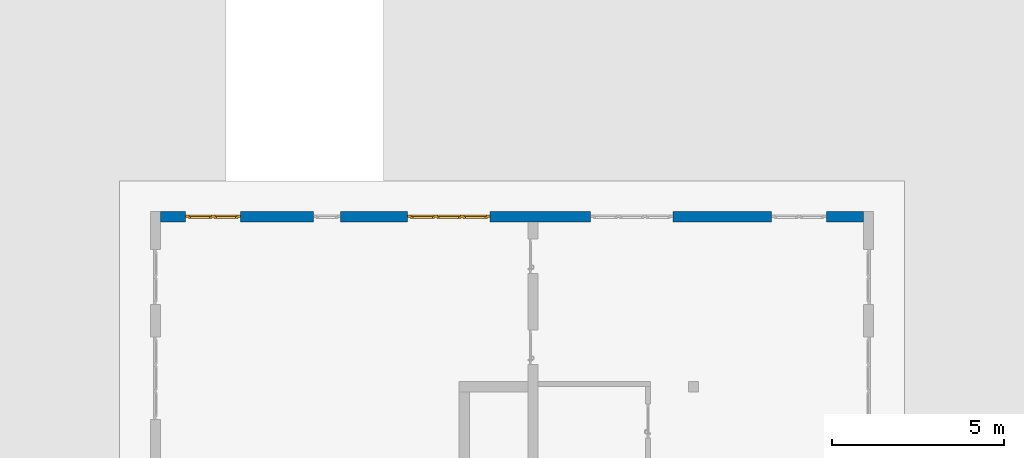
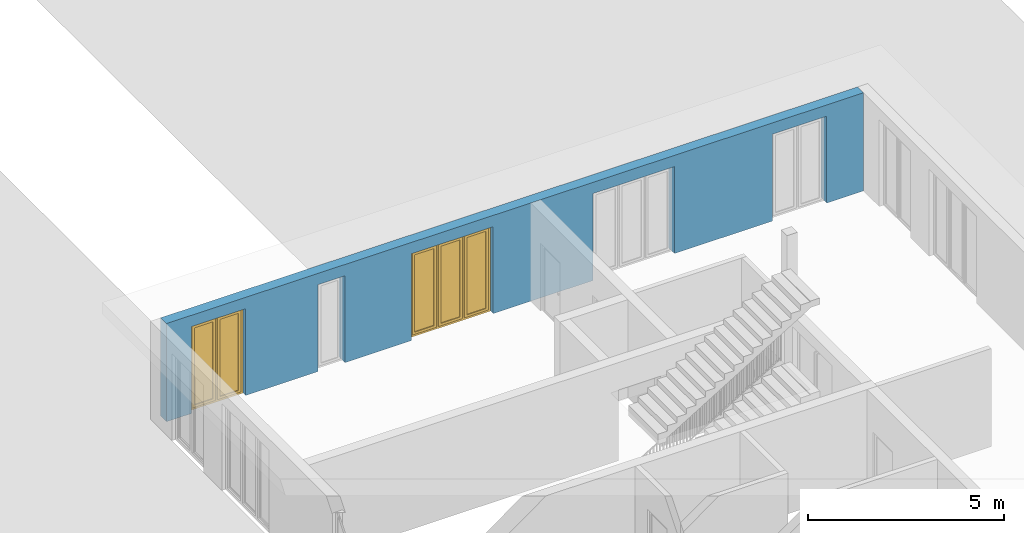
# One storey, part 15 of 23: 2 windows, 1 wall, 5 openings.
"""IFC4 building model written with IfcOpenShell, lengths in metres."""

from ifc_helpers import new_model, entity, si_unit, converted_unit, derived_unit, direction, frame, origin_with_axes, place, context, subcontext, project, spatial, polygons, source, transform, mapped, material, type_object, element, fill, save


model = new_model("IFC4")

# Units and contexts
model_context = context("Model", 3, precision=1e-05, world=origin_with_axes(), true_north=direction((0.0, 1.0)))
body_context = subcontext(model_context, "Body", "Model", "MODEL_VIEW")
ifc_project = project(units=[si_unit("LENGTHUNIT", "METRE"), si_unit("AREAUNIT", "SQUARE_METRE"), si_unit("VOLUMEUNIT", "CUBIC_METRE"), converted_unit("PLANEANGLEUNIT", "DEGREE", entity("IfcPlaneAngleMeasure", 0.0174532925199), si_unit("PLANEANGLEUNIT", "RADIAN"), dimensions=[0, 0, 0, 0, 0, 0, 0]), converted_unit("TIMEUNIT", "Year", entity("IfcTimeMeasure", 31556926.0), si_unit("TIMEUNIT", "SECOND"), dimensions=[0, 0, 1, 0, 0, 0, 0]), si_unit("MASSUNIT", "GRAM", prefix="KILO"), si_unit("THERMODYNAMICTEMPERATUREUNIT", "DEGREE_CELSIUS"), si_unit("LUMINOUSINTENSITYUNIT", "LUMEN"), si_unit("ENERGYUNIT", "JOULE", prefix="MEGA"), derived_unit("THERMALCONDUCTANCEUNIT", [(si_unit("POWERUNIT", "WATT"), 1), (si_unit("LENGTHUNIT", "METRE"), -1), (si_unit("THERMODYNAMICTEMPERATUREUNIT", "KELVIN"), -1)]), derived_unit("SPECIFICHEATCAPACITYUNIT", [(si_unit("ENERGYUNIT", "JOULE"), 1), (si_unit("MASSUNIT", "GRAM", prefix="KILO"), -1), (si_unit("THERMODYNAMICTEMPERATUREUNIT", "KELVIN"), -1)]), derived_unit("MASSDENSITYUNIT", [(si_unit("MASSUNIT", "GRAM", prefix="KILO"), 1), (si_unit("VOLUMEUNIT", "CUBIC_METRE"), -1)])], contexts=[model_context])

# Site, building, storey
site_placement = place(None, origin_with_axes())
site = spatial("IfcSite", under=ifc_project, at=site_placement, CompositionType="ELEMENT")
building_placement = place(site_placement, origin_with_axes())
building = spatial("IfcBuilding", under=site, at=building_placement, CompositionType="ELEMENT")
storey_placement = place(building_placement, origin_with_axes())
storey = spatial("IfcBuildingStorey", under=building, at=storey_placement, Name="0. Geschoss", CompositionType="ELEMENT", Elevation=0.0)

# Wall, openings, windows
ifc_material = material()
wall_type = type_object("IfcWallType", Name="300", PredefinedType="NOTDEFINED")
wall_placement = place(storey_placement, frame((-11.7421993804, 8.92118776896, 0.0), z_axis=(0.0, 0.0, 1.0), x_axis=(1.0, 0.0, 0.0)))
wall = element("IfcWall", 1, at=wall_placement, inside=storey, type_object=wall_type, material=ifc_material, Name="Wand-001", PredefinedType="NOTDEFINED", context=body_context, shape_type="Tessellation", body=[
    polygons([(15.23, -0.1, 0.0), (15.23, -0.3, 0.0), (15.23, -0.3, 2.7), (15.23, 0.0, 2.7), (15.23, 0.0, 0.0), (18.102139809, 0.0, 0.0), (18.102139809, -0.3, 0.0), (18.102139809, -0.3, 2.7), (19.702139809, -0.3, 2.7), (19.702139809, -0.3, 0.0), (20.78, -0.3, 0.0), (20.78, -0.3, 3.05), (0.3, -0.3, 3.05), (0.3, -0.3, 0.0), (1.0288518641, -0.3, 0.0), (1.0288518641, -0.3, 2.7), (2.6288518641, -0.3, 2.7), (2.6288518641, -0.3, 0.0), (4.75, -0.3, 0.0), (4.75, -0.3, 2.7), (5.55, -0.3, 2.7), (5.55, -0.3, 0.0), (7.50089858046, -0.3, 0.0), (7.50089858046, -0.3, 2.7), (9.90089858046, -0.3, 2.7), (9.90089858046, -0.3, 0.0), (12.83, -0.3, 0.0), (12.83, -0.3, 2.7), (12.83, 0.0, 2.7), (12.83, 0.0, 0.0), (9.90089858046, 0.0, 0.0), (9.90089858046, 0.0, 2.7), (7.50089858046, 0.0, 2.7), (7.50089858046, 0.0, 0.0), (5.55, 0.0, 0.0), (5.55, 0.0, 2.7), (4.75, 0.0, 2.7), (4.75, 0.0, 0.0), (2.6288518641, 0.0, 0.0), (2.6288518641, 0.0, 2.7), (1.0288518641, 0.0, 2.7), (1.0288518641, 0.0, 0.0), (0.3, 0.0, 0.0), (0.3, 0.0, 3.05), (20.78, 0.0, 3.05), (20.78, 0.0, 0.0), (19.702139809, 0.0, 0.0), (19.702139809, 0.0, 2.7), (18.102139809, 0.0, 2.7), (12.83, -0.1, 0.0)], [[[1, 2, 3, 4, 5]], [[2, 1, 5, 6, 7]], [[3, 2, 7, 8, 9, 10, 11, 12, 13, 14, 15, 16, 17, 18, 19, 20, 21, 22, 23, 24, 25, 26, 27, 28]], [[4, 3, 28, 29]], [[6, 5, 4, 29, 30, 31, 32, 33, 34, 35, 36, 37, 38, 39, 40, 41, 42, 43, 44, 45, 46, 47, 48, 49]], [[6, 49, 8, 7]], [[8, 49, 48, 9]], [[48, 47, 10, 9]], [[46, 11, 10, 47]], [[12, 11, 46, 45]], [[45, 44, 13, 12]], [[44, 43, 14, 13]], [[15, 14, 43, 42]], [[16, 15, 42, 41]], [[40, 17, 16, 41]], [[18, 17, 40, 39]], [[19, 18, 39, 38]], [[20, 19, 38, 37]], [[36, 21, 20, 37]], [[22, 21, 36, 35]], [[22, 35, 34, 23]], [[34, 33, 24, 23]], [[24, 33, 32, 25]], [[32, 31, 26, 25]], [[50, 27, 26, 31, 30]], [[28, 27, 50, 30, 29]]], closed=True),
])
opening_1_placement = place(wall_placement, frame((1.8288518641, 0.0, 0.0), z_axis=(0.0, 0.0, 1.0), x_axis=(1.0, 0.0, 0.0)))
opening_1 = element("IfcOpeningElement", 2, at=opening_1_placement, cuts=wall, Name="Fenster-001", context=body_context, identifier="Reference", shape_type="Tessellation", body=[
    polygons([(-0.8, -0.1, 0.0), (-0.8, -0.1, 2.7), (-0.8, 0.000999999999998, 2.7), (-0.8, 0.000999999999998, 0.0), (-0.8, -0.301, 0.0), (-0.8, -0.301, 2.7), (0.8, -0.1, 2.7), (0.8, 0.000999999999999, 2.7), (0.8, -0.301, 2.7), (0.8, 0.000999999999999, 0.0), (0.8, -0.1, 0.0), (0.8, -0.301, 0.0)], [[[1, 2, 3, 4]], [[2, 1, 5, 6]], [[7, 8, 3, 2, 6, 9]], [[8, 10, 4, 3]], [[1, 4, 10, 11, 12, 5]], [[6, 5, 12, 9]], [[7, 11, 10, 8]], [[11, 7, 9, 12]]], closed=True),
])
opening_2_placement = place(wall_placement, frame((8.70089858046, 0.0, 0.0), z_axis=(0.0, 0.0, 1.0), x_axis=(1.0, 0.0, 0.0)))
opening_2 = element("IfcOpeningElement", 3, at=opening_2_placement, cuts=wall, Name="Fenster-002", context=body_context, identifier="Reference", shape_type="Tessellation", body=[
    polygons([(-1.2, -0.1, 0.0), (-1.2, -0.1, 2.7), (-1.2, 0.000999999999999, 2.7), (-1.2, 0.000999999999999, 0.0), (-1.2, -0.301, 0.0), (-1.2, -0.301, 2.7), (1.2, -0.1, 2.7), (1.2, 0.001, 2.7), (1.2, -0.301, 2.7), (1.2, 0.001, 0.0), (1.2, -0.1, 0.0), (1.2, -0.301, 0.0)], [[[1, 2, 3, 4]], [[2, 1, 5, 6]], [[7, 8, 3, 2, 6, 9]], [[8, 10, 4, 3]], [[1, 4, 10, 11, 12, 5]], [[6, 5, 12, 9]], [[7, 11, 10, 8]], [[11, 7, 9, 12]]], closed=True),
])
opening_3_placement = place(wall_placement, frame((5.15, 0.0, 0.0), z_axis=(0.0, 0.0, 1.0), x_axis=(1.0, 0.0, 0.0)))
element("IfcOpeningElement", 4, at=opening_3_placement, cuts=wall, Name="Fenster-003", context=body_context, identifier="Reference", shape_type="Tessellation", body=[
    polygons([(-0.4, -0.1, 0.0), (-0.4, -0.1, 2.7), (-0.4, 0.001, 2.7), (-0.4, 0.001, 0.0), (-0.4, -0.301, 0.0), (-0.4, -0.301, 2.7), (0.4, -0.1, 2.7), (0.4, 0.001, 2.7), (0.4, -0.301, 2.7), (0.4, 0.001, 0.0), (0.4, -0.1, 0.0), (0.4, -0.301, 0.0)], [[[1, 2, 3, 4]], [[2, 1, 5, 6]], [[7, 8, 3, 2, 6, 9]], [[8, 10, 4, 3]], [[1, 4, 10, 11, 12, 5]], [[6, 5, 12, 9]], [[7, 11, 10, 8]], [[11, 7, 9, 12]]], closed=True),
])
opening_4_placement = place(wall_placement, frame((18.902139809, 0.0, 0.0), z_axis=(0.0, 0.0, 1.0), x_axis=(1.0, 0.0, 0.0)))
element("IfcOpeningElement", 5, at=opening_4_placement, cuts=wall, Name="Fenster-001", context=body_context, identifier="Reference", shape_type="Tessellation", body=[
    polygons([(-0.8, -0.1, 0.0), (-0.8, -0.1, 2.7), (-0.8, 0.001, 2.7), (-0.8, 0.001, 0.0), (-0.8, -0.301, 0.0), (-0.8, -0.301, 2.7), (0.8, -0.1, 2.7), (0.8, 0.001, 2.7), (0.8, -0.301, 2.7), (0.8, 0.001, 0.0), (0.8, -0.1, 0.0), (0.8, -0.301, 0.0)], [[[1, 2, 3, 4]], [[2, 1, 5, 6]], [[7, 8, 3, 2, 6, 9]], [[8, 10, 4, 3]], [[1, 4, 10, 11, 12, 5]], [[6, 5, 12, 9]], [[7, 11, 10, 8]], [[11, 7, 9, 12]]], closed=True),
])
opening_5_placement = place(wall_placement, frame((14.03, 0.0, 0.0), z_axis=(0.0, 0.0, 1.0), x_axis=(1.0, 0.0, 0.0)))
element("IfcOpeningElement", 6, at=opening_5_placement, cuts=wall, Name="Fenster-002", context=body_context, identifier="Reference", shape_type="Tessellation", body=[
    polygons([(-1.2, -0.1, 0.0), (-1.2, -0.1, 2.7), (-1.2, 0.001, 2.7), (-1.2, 0.001, 0.0), (-1.2, -0.301, 0.0), (-1.2, -0.301, 2.7), (1.2, -0.1, 2.7), (1.2, 0.001, 2.7), (1.2, -0.301, 2.7), (1.2, 0.001, 0.0), (1.2, -0.1, 0.0), (1.2, -0.301, 0.0)], [[[1, 2, 3, 4]], [[2, 1, 5, 6]], [[7, 8, 3, 2, 6, 9]], [[8, 10, 4, 3]], [[1, 4, 10, 11, 12, 5]], [[6, 5, 12, 9]], [[7, 11, 10, 8]], [[11, 7, 9, 12]]], closed=True),
])
window_type_1 = type_object("IfcWindowType", Name="2-1+1 26", PartitioningType="DOUBLE_PANEL_VERTICAL", PredefinedType="WINDOW")
shared_shape_1 = source(origin_with_axes(), body_context, "Body", "Tessellation", [
    polygons([(0.8, -0.07, 0.0), (0.7, -0.07, 0.1), (0.7, 0.0, 0.1), (0.8, 0.0, 0.0), (0.8, -0.07, 2.7), (0.7, -0.07, 2.6), (0.7, 0.0, 2.6), (0.8, 0.0, 2.7)], [[[1, 2, 3, 4]], [[1, 5, 6, 2]], [[2, 6, 7, 3]], [[4, 3, 7, 8]], [[5, 1, 4, 8]], [[6, 5, 8, 7]]], closed=True),
    polygons([(-0.8, -0.07, 0.0), (-0.8, -0.07, 2.7), (-0.8, 0.0, 2.7), (-0.8, 0.0, 0.0), (-0.7, -0.07, 0.1), (-0.7, -0.07, 2.6), (-0.7, 0.0, 2.6), (-0.7, 0.0, 0.1)], [[[1, 2, 3, 4]], [[1, 5, 6, 2]], [[2, 6, 7, 3]], [[4, 3, 7, 8]], [[5, 1, 4, 8]], [[6, 5, 8, 7]]], closed=True),
    polygons([(0.8, -0.07, 0.0), (-0.8, -0.07, 0.0), (-0.8, 0.0, 0.0), (0.8, 0.0, 0.0), (0.7, -0.07, 0.1), (0.05, -0.07, 0.1), (-0.05, -0.07, 0.1), (-0.7, -0.07, 0.1), (-0.7, 0.0, 0.1), (-0.05, 0.0, 0.1), (0.05, 0.0, 0.1), (0.7, 0.0, 0.1)], [[[1, 2, 3, 4]], [[1, 5, 6, 7, 8, 2]], [[2, 8, 9, 3]], [[4, 3, 9, 10, 11, 12]], [[5, 1, 4, 12]], [[6, 5, 12, 11]], [[7, 6, 11, 10]], [[8, 7, 10, 9]]], closed=True),
    polygons([(0.8, -0.07, 2.7), (0.7, -0.07, 2.6), (0.7, 0.0, 2.6), (0.8, 0.0, 2.7), (-0.8, -0.07, 2.7), (-0.7, -0.07, 2.6), (-0.05, -0.07, 2.6), (0.05, -0.07, 2.6), (0.05, 0.0, 2.6), (-0.05, 0.0, 2.6), (-0.7, 0.0, 2.6), (-0.8, 0.0, 2.7)], [[[1, 2, 3, 4]], [[1, 5, 6, 7, 8, 2]], [[2, 8, 9, 3]], [[4, 3, 9, 10, 11, 12]], [[5, 1, 4, 12]], [[6, 5, 12, 11]], [[7, 6, 11, 10]], [[8, 7, 10, 9]]], closed=True),
    polygons([(0.05, -0.07, 0.1), (-0.05, -0.07, 0.1), (-0.05, 0.0, 0.1), (0.05, 0.0, 0.1), (0.05, -0.07, 2.6), (-0.05, -0.07, 2.6), (-0.05, 0.0, 2.6), (0.05, 0.0, 2.6)], [[[1, 2, 3, 4]], [[1, 5, 6, 2]], [[2, 6, 7, 3]], [[4, 3, 7, 8]], [[5, 1, 4, 8]], [[6, 5, 8, 7]]], closed=True),
    polygons([(0.72, 0.0, 0.08), (0.65, 0.0, 0.15), (0.65, 0.03, 0.15), (0.72, 0.03, 0.08), (0.72, 0.0, 2.62), (0.65, 0.0, 2.55), (0.65, 0.03, 2.55), (0.72, 0.03, 2.62)], [[[1, 2, 3, 4]], [[1, 5, 6, 2]], [[2, 6, 7, 3]], [[4, 3, 7, 8]], [[5, 1, 4, 8]], [[6, 5, 8, 7]]], closed=True),
    polygons([(0.03, 0.0, 0.08), (0.03, 0.03, 0.08), (0.1, 0.03, 0.15), (0.1, 0.0, 0.15), (0.03, 0.0, 2.62), (0.03, 0.03, 2.62), (0.1, 0.03, 2.55), (0.1, 0.0, 2.55)], [[[1, 2, 3, 4]], [[5, 6, 2, 1]], [[2, 6, 7, 3]], [[4, 3, 7, 8]], [[1, 4, 8, 5]], [[8, 7, 6, 5]]], closed=True),
    polygons([(0.72, 0.0, 0.08), (0.03, 0.0, 0.08), (0.03, 0.03, 0.08), (0.72, 0.03, 0.08), (0.65, 0.0, 0.15), (0.1, 0.0, 0.15), (0.1, 0.03, 0.15), (0.65, 0.03, 0.15)], [[[1, 2, 3, 4]], [[1, 5, 6, 2]], [[2, 6, 7, 3]], [[4, 3, 7, 8]], [[5, 1, 4, 8]], [[6, 5, 8, 7]]], closed=True),
    polygons([(0.72, 0.0, 2.62), (0.72, 0.03, 2.62), (0.03, 0.03, 2.62), (0.03, 0.0, 2.62), (0.65, 0.0, 2.55), (0.65, 0.03, 2.55), (0.1, 0.03, 2.55), (0.1, 0.0, 2.55)], [[[1, 2, 3, 4]], [[5, 6, 2, 1]], [[2, 6, 7, 3]], [[4, 3, 7, 8]], [[1, 4, 8, 5]], [[8, 7, 6, 5]]], closed=True),
    polygons([(0.7, -0.03, 0.1), (0.65, -0.03, 0.15), (0.65, 0.0, 0.15), (0.7, 0.0, 0.1), (0.7, -0.03, 2.6), (0.65, -0.03, 2.55), (0.65, 0.0, 2.55), (0.7, 0.0, 2.6)], [[[1, 2, 3, 4]], [[1, 5, 6, 2]], [[2, 6, 7, 3]], [[4, 3, 7, 8]], [[5, 1, 4, 8]], [[6, 5, 8, 7]]], closed=True),
    polygons([(0.05, -0.03, 0.1), (0.05, 0.0, 0.1), (0.1, 0.0, 0.15), (0.1, -0.03, 0.15), (0.05, -0.03, 2.6), (0.05, 0.0, 2.6), (0.1, 0.0, 2.55), (0.1, -0.03, 2.55)], [[[1, 2, 3, 4]], [[5, 6, 2, 1]], [[2, 6, 7, 3]], [[4, 3, 7, 8]], [[1, 4, 8, 5]], [[8, 7, 6, 5]]], closed=True),
    polygons([(0.7, -0.03, 0.1), (0.05, -0.03, 0.1), (0.05, 0.0, 0.1), (0.7, 0.0, 0.1), (0.65, -0.03, 0.15), (0.1, -0.03, 0.15), (0.1, 0.0, 0.15), (0.65, 0.0, 0.15)], [[[1, 2, 3, 4]], [[1, 5, 6, 2]], [[2, 6, 7, 3]], [[4, 3, 7, 8]], [[5, 1, 4, 8]], [[6, 5, 8, 7]]], closed=True),
    polygons([(0.7, -0.03, 2.6), (0.7, 0.0, 2.6), (0.05, 0.0, 2.6), (0.05, -0.03, 2.6), (0.65, -0.03, 2.55), (0.65, 0.0, 2.55), (0.1, 0.0, 2.55), (0.1, -0.03, 2.55)], [[[1, 2, 3, 4]], [[5, 6, 2, 1]], [[2, 6, 7, 3]], [[4, 3, 7, 8]], [[1, 4, 8, 5]], [[8, 7, 6, 5]]], closed=True),
    polygons([(0.65, -0.005, 0.15), (0.1, -0.005, 0.15), (0.1, 0.005, 0.15), (0.65, 0.005, 0.15), (0.65, -0.005, 2.55), (0.1, -0.005, 2.55), (0.1, 0.005, 2.55), (0.65, 0.005, 2.55)], [[[1, 2, 3, 4]], [[1, 5, 6, 2]], [[2, 6, 7, 3]], [[4, 3, 7, 8]], [[5, 1, 4, 8]], [[6, 5, 8, 7]]], closed=True),
    polygons([(-0.03, 0.0, 0.08), (-0.1, 0.0, 0.15), (-0.1, 0.03, 0.15), (-0.03, 0.03, 0.08), (-0.03, 0.0, 2.62), (-0.1, 0.0, 2.55), (-0.1, 0.03, 2.55), (-0.03, 0.03, 2.62)], [[[1, 2, 3, 4]], [[1, 5, 6, 2]], [[2, 6, 7, 3]], [[4, 3, 7, 8]], [[5, 1, 4, 8]], [[6, 5, 8, 7]]], closed=True),
    polygons([(-0.72, 0.0, 0.08), (-0.72, 0.03, 0.08), (-0.65, 0.03, 0.15), (-0.65, 0.0, 0.15), (-0.72, 0.0, 2.62), (-0.72, 0.03, 2.62), (-0.65, 0.03, 2.55), (-0.65, 0.0, 2.55)], [[[1, 2, 3, 4]], [[5, 6, 2, 1]], [[2, 6, 7, 3]], [[4, 3, 7, 8]], [[1, 4, 8, 5]], [[8, 7, 6, 5]]], closed=True),
    polygons([(-0.03, 0.0, 0.08), (-0.72, 0.0, 0.08), (-0.72, 0.03, 0.08), (-0.03, 0.03, 0.08), (-0.1, 0.0, 0.15), (-0.65, 0.0, 0.15), (-0.65, 0.03, 0.15), (-0.1, 0.03, 0.15)], [[[1, 2, 3, 4]], [[1, 5, 6, 2]], [[2, 6, 7, 3]], [[4, 3, 7, 8]], [[5, 1, 4, 8]], [[6, 5, 8, 7]]], closed=True),
    polygons([(-0.03, 0.0, 2.62), (-0.03, 0.03, 2.62), (-0.72, 0.03, 2.62), (-0.72, 0.0, 2.62), (-0.1, 0.0, 2.55), (-0.1, 0.03, 2.55), (-0.65, 0.03, 2.55), (-0.65, 0.0, 2.55)], [[[1, 2, 3, 4]], [[5, 6, 2, 1]], [[2, 6, 7, 3]], [[4, 3, 7, 8]], [[1, 4, 8, 5]], [[8, 7, 6, 5]]], closed=True),
    polygons([(-0.05, -0.03, 0.1), (-0.1, -0.03, 0.15), (-0.1, 0.0, 0.15), (-0.05, 0.0, 0.1), (-0.05, -0.03, 2.6), (-0.1, -0.03, 2.55), (-0.1, 0.0, 2.55), (-0.05, 0.0, 2.6)], [[[1, 2, 3, 4]], [[1, 5, 6, 2]], [[2, 6, 7, 3]], [[4, 3, 7, 8]], [[5, 1, 4, 8]], [[6, 5, 8, 7]]], closed=True),
    polygons([(-0.7, -0.03, 0.1), (-0.7, 0.0, 0.1), (-0.65, 0.0, 0.15), (-0.65, -0.03, 0.15), (-0.7, -0.03, 2.6), (-0.7, 0.0, 2.6), (-0.65, 0.0, 2.55), (-0.65, -0.03, 2.55)], [[[1, 2, 3, 4]], [[5, 6, 2, 1]], [[2, 6, 7, 3]], [[4, 3, 7, 8]], [[1, 4, 8, 5]], [[8, 7, 6, 5]]], closed=True),
    polygons([(-0.05, -0.03, 0.1), (-0.7, -0.03, 0.1), (-0.7, 0.0, 0.1), (-0.05, 0.0, 0.1), (-0.1, -0.03, 0.15), (-0.65, -0.03, 0.15), (-0.65, 0.0, 0.15), (-0.1, 0.0, 0.15)], [[[1, 2, 3, 4]], [[1, 5, 6, 2]], [[2, 6, 7, 3]], [[4, 3, 7, 8]], [[5, 1, 4, 8]], [[6, 5, 8, 7]]], closed=True),
    polygons([(-0.05, -0.03, 2.6), (-0.05, 0.0, 2.6), (-0.7, 0.0, 2.6), (-0.7, -0.03, 2.6), (-0.1, -0.03, 2.55), (-0.1, 0.0, 2.55), (-0.65, 0.0, 2.55), (-0.65, -0.03, 2.55)], [[[1, 2, 3, 4]], [[5, 6, 2, 1]], [[2, 6, 7, 3]], [[4, 3, 7, 8]], [[1, 4, 8, 5]], [[8, 7, 6, 5]]], closed=True),
    polygons([(-0.1, -0.005, 0.15), (-0.65, -0.005, 0.15), (-0.65, 0.005, 0.15), (-0.1, 0.005, 0.15), (-0.1, -0.005, 2.55), (-0.65, -0.005, 2.55), (-0.65, 0.005, 2.55), (-0.1, 0.005, 2.55)], [[[1, 2, 3, 4]], [[1, 5, 6, 2]], [[2, 6, 7, 3]], [[4, 3, 7, 8]], [[5, 1, 4, 8]], [[6, 5, 8, 7]]], closed=True),
])
window_1_placement = place(opening_1_placement, frame((0.8, 0.0, 0.0), z_axis=(0.0, 0.0, 1.0), x_axis=(-1.0, 0.0, 0.0)))
window_1 = element("IfcWindow", 7, at=window_1_placement, inside=storey, type_object=window_type_1, Name="Fenster-001", OverallHeight=2.7, OverallWidth=1.6, PredefinedType="WINDOW", context=body_context, shape_type="MappedRepresentation", body=[
    mapped(shared_shape_1, transform((0.8, 0.17, 0.0))),
])
fill(opening_1, window_1)
window_type_2 = type_object("IfcWindowType", Name="3-1+1+1 26", PartitioningType="TRIPLE_PANEL_VERTICAL", PredefinedType="WINDOW")
shared_shape_2 = source(origin_with_axes(), body_context, "Body", "Tessellation", [
    polygons([(1.2, -0.07, 0.0), (1.1, -0.07, 0.1), (1.1, 0.0, 0.1), (1.2, 0.0, 0.0), (1.2, -0.07, 2.7), (1.1, -0.07, 2.6), (1.1, 0.0, 2.6), (1.2, 0.0, 2.7)], [[[1, 2, 3, 4]], [[1, 5, 6, 2]], [[2, 6, 7, 3]], [[4, 3, 7, 8]], [[5, 1, 4, 8]], [[6, 5, 8, 7]]], closed=True),
    polygons([(-1.2, -0.07, 0.0), (-1.2, -0.07, 2.7), (-1.2, 0.0, 2.7), (-1.2, 0.0, 0.0), (-1.1, -0.07, 0.1), (-1.1, -0.07, 2.6), (-1.1, 0.0, 2.6), (-1.1, 0.0, 0.1)], [[[1, 2, 3, 4]], [[1, 5, 6, 2]], [[2, 6, 7, 3]], [[4, 3, 7, 8]], [[5, 1, 4, 8]], [[6, 5, 8, 7]]], closed=True),
    polygons([(1.2, -0.07, 0.0), (-1.2, -0.07, 0.0), (-1.2, 0.0, 0.0), (1.2, 0.0, 0.0), (1.1, -0.07, 0.1), (0.433333333333, -0.07, 0.1), (0.333333333333, -0.07, 0.1), (-0.333333333333, -0.07, 0.1), (-0.433333333333, -0.07, 0.1), (-1.1, -0.07, 0.1), (-1.1, 0.0, 0.1), (-0.433333333333, 0.0, 0.1), (-0.333333333333, 0.0, 0.1), (0.333333333333, 0.0, 0.1), (0.433333333333, 0.0, 0.1), (1.1, 0.0, 0.1)], [[[1, 2, 3, 4]], [[1, 5, 6, 7, 8, 9, 10, 2]], [[2, 10, 11, 3]], [[4, 3, 11, 12, 13, 14, 15, 16]], [[5, 1, 4, 16]], [[6, 5, 16, 15]], [[7, 6, 15, 14]], [[8, 7, 14, 13]], [[9, 8, 13, 12]], [[10, 9, 12, 11]]], closed=True),
    polygons([(1.2, -0.07, 2.7), (1.1, -0.07, 2.6), (1.1, 0.0, 2.6), (1.2, 0.0, 2.7), (-1.2, -0.07, 2.7), (-1.1, -0.07, 2.6), (-0.433333333333, -0.07, 2.6), (-0.333333333333, -0.07, 2.6), (0.333333333333, -0.07, 2.6), (0.433333333333, -0.07, 2.6), (0.433333333333, 0.0, 2.6), (0.333333333333, 0.0, 2.6), (-0.333333333333, 0.0, 2.6), (-0.433333333333, 0.0, 2.6), (-1.1, 0.0, 2.6), (-1.2, 0.0, 2.7)], [[[1, 2, 3, 4]], [[1, 5, 6, 7, 8, 9, 10, 2]], [[2, 10, 11, 3]], [[4, 3, 11, 12, 13, 14, 15, 16]], [[5, 1, 4, 16]], [[6, 5, 16, 15]], [[7, 6, 15, 14]], [[8, 7, 14, 13]], [[9, 8, 13, 12]], [[10, 9, 12, 11]]], closed=True),
    polygons([(-0.333333333333, -0.07, 0.1), (-0.433333333333, -0.07, 0.1), (-0.433333333333, 0.0, 0.1), (-0.333333333333, 0.0, 0.1), (-0.333333333333, -0.07, 2.6), (-0.433333333333, -0.07, 2.6), (-0.433333333333, 0.0, 2.6), (-0.333333333333, 0.0, 2.6)], [[[1, 2, 3, 4]], [[1, 5, 6, 2]], [[2, 6, 7, 3]], [[4, 3, 7, 8]], [[5, 1, 4, 8]], [[6, 5, 8, 7]]], closed=True),
    polygons([(0.433333333333, -0.07, 0.1), (0.333333333333, -0.07, 0.1), (0.333333333333, 0.0, 0.1), (0.433333333333, 0.0, 0.1), (0.433333333333, -0.07, 2.6), (0.333333333333, -0.07, 2.6), (0.333333333333, 0.0, 2.6), (0.433333333333, 0.0, 2.6)], [[[1, 2, 3, 4]], [[1, 5, 6, 2]], [[2, 6, 7, 3]], [[4, 3, 7, 8]], [[5, 1, 4, 8]], [[6, 5, 8, 7]]], closed=True),
    polygons([(1.12, 0.0, 0.08), (1.05, 0.0, 0.15), (1.05, 0.03, 0.15), (1.12, 0.03, 0.08), (1.12, 0.0, 2.62), (1.05, 0.0, 2.55), (1.05, 0.03, 2.55), (1.12, 0.03, 2.62)], [[[1, 2, 3, 4]], [[1, 5, 6, 2]], [[2, 6, 7, 3]], [[4, 3, 7, 8]], [[5, 1, 4, 8]], [[6, 5, 8, 7]]], closed=True),
    polygons([(0.413333333333, 0.0, 0.08), (0.413333333333, 0.03, 0.08), (0.483333333333, 0.03, 0.15), (0.483333333333, 0.0, 0.15), (0.413333333333, 0.0, 2.62), (0.413333333333, 0.03, 2.62), (0.483333333333, 0.03, 2.55), (0.483333333333, 0.0, 2.55)], [[[1, 2, 3, 4]], [[5, 6, 2, 1]], [[2, 6, 7, 3]], [[4, 3, 7, 8]], [[1, 4, 8, 5]], [[8, 7, 6, 5]]], closed=True),
    polygons([(1.12, 0.0, 0.08), (0.413333333333, 0.0, 0.08), (0.413333333333, 0.03, 0.08), (1.12, 0.03, 0.08), (1.05, 0.0, 0.15), (0.483333333333, 0.0, 0.15), (0.483333333333, 0.03, 0.15), (1.05, 0.03, 0.15)], [[[1, 2, 3, 4]], [[1, 5, 6, 2]], [[2, 6, 7, 3]], [[4, 3, 7, 8]], [[5, 1, 4, 8]], [[6, 5, 8, 7]]], closed=True),
    polygons([(1.12, 0.0, 2.62), (1.12, 0.03, 2.62), (0.413333333333, 0.03, 2.62), (0.413333333333, 0.0, 2.62), (1.05, 0.0, 2.55), (1.05, 0.03, 2.55), (0.483333333333, 0.03, 2.55), (0.483333333333, 0.0, 2.55)], [[[1, 2, 3, 4]], [[5, 6, 2, 1]], [[2, 6, 7, 3]], [[4, 3, 7, 8]], [[1, 4, 8, 5]], [[8, 7, 6, 5]]], closed=True),
    polygons([(1.1, -0.03, 0.1), (1.05, -0.03, 0.15), (1.05, 0.0, 0.15), (1.1, 0.0, 0.1), (1.1, -0.03, 2.6), (1.05, -0.03, 2.55), (1.05, 0.0, 2.55), (1.1, 0.0, 2.6)], [[[1, 2, 3, 4]], [[1, 5, 6, 2]], [[2, 6, 7, 3]], [[4, 3, 7, 8]], [[5, 1, 4, 8]], [[6, 5, 8, 7]]], closed=True),
    polygons([(0.433333333333, -0.03, 0.1), (0.433333333333, 0.0, 0.1), (0.483333333333, 0.0, 0.15), (0.483333333333, -0.03, 0.15), (0.433333333333, -0.03, 2.6), (0.433333333333, 0.0, 2.6), (0.483333333333, 0.0, 2.55), (0.483333333333, -0.03, 2.55)], [[[1, 2, 3, 4]], [[5, 6, 2, 1]], [[2, 6, 7, 3]], [[4, 3, 7, 8]], [[1, 4, 8, 5]], [[8, 7, 6, 5]]], closed=True),
    polygons([(1.1, -0.03, 0.1), (0.433333333333, -0.03, 0.1), (0.433333333333, 0.0, 0.1), (1.1, 0.0, 0.1), (1.05, -0.03, 0.15), (0.483333333333, -0.03, 0.15), (0.483333333333, 0.0, 0.15), (1.05, 0.0, 0.15)], [[[1, 2, 3, 4]], [[1, 5, 6, 2]], [[2, 6, 7, 3]], [[4, 3, 7, 8]], [[5, 1, 4, 8]], [[6, 5, 8, 7]]], closed=True),
    polygons([(1.1, -0.03, 2.6), (1.1, 0.0, 2.6), (0.433333333333, 0.0, 2.6), (0.433333333333, -0.03, 2.6), (1.05, -0.03, 2.55), (1.05, 0.0, 2.55), (0.483333333333, 0.0, 2.55), (0.483333333333, -0.03, 2.55)], [[[1, 2, 3, 4]], [[5, 6, 2, 1]], [[2, 6, 7, 3]], [[4, 3, 7, 8]], [[1, 4, 8, 5]], [[8, 7, 6, 5]]], closed=True),
    polygons([(1.05, -0.005, 0.15), (0.483333333333, -0.005, 0.15), (0.483333333333, 0.005, 0.15), (1.05, 0.005, 0.15), (1.05, -0.005, 2.55), (0.483333333333, -0.005, 2.55), (0.483333333333, 0.005, 2.55), (1.05, 0.005, 2.55)], [[[1, 2, 3, 4]], [[1, 5, 6, 2]], [[2, 6, 7, 3]], [[4, 3, 7, 8]], [[5, 1, 4, 8]], [[6, 5, 8, 7]]], closed=True),
    polygons([(0.353333333333, 0.0, 0.08), (0.283333333333, 0.0, 0.15), (0.283333333333, 0.03, 0.15), (0.353333333333, 0.03, 0.08), (0.353333333333, 0.0, 2.62), (0.283333333333, 0.0, 2.55), (0.283333333333, 0.03, 2.55), (0.353333333333, 0.03, 2.62)], [[[1, 2, 3, 4]], [[1, 5, 6, 2]], [[2, 6, 7, 3]], [[4, 3, 7, 8]], [[5, 1, 4, 8]], [[6, 5, 8, 7]]], closed=True),
    polygons([(-0.353333333333, 0.0, 0.08), (-0.353333333333, 0.03, 0.08), (-0.283333333333, 0.03, 0.15), (-0.283333333333, 0.0, 0.15), (-0.353333333333, 0.0, 2.62), (-0.353333333333, 0.03, 2.62), (-0.283333333333, 0.03, 2.55), (-0.283333333333, 0.0, 2.55)], [[[1, 2, 3, 4]], [[5, 6, 2, 1]], [[2, 6, 7, 3]], [[4, 3, 7, 8]], [[1, 4, 8, 5]], [[8, 7, 6, 5]]], closed=True),
    polygons([(0.353333333333, 0.0, 0.08), (-0.353333333333, 0.0, 0.08), (-0.353333333333, 0.03, 0.08), (0.353333333333, 0.03, 0.08), (0.283333333333, 0.0, 0.15), (-0.283333333333, 0.0, 0.15), (-0.283333333333, 0.03, 0.15), (0.283333333333, 0.03, 0.15)], [[[1, 2, 3, 4]], [[1, 5, 6, 2]], [[2, 6, 7, 3]], [[4, 3, 7, 8]], [[5, 1, 4, 8]], [[6, 5, 8, 7]]], closed=True),
    polygons([(0.353333333333, 0.0, 2.62), (0.353333333333, 0.03, 2.62), (-0.353333333333, 0.03, 2.62), (-0.353333333333, 0.0, 2.62), (0.283333333333, 0.0, 2.55), (0.283333333333, 0.03, 2.55), (-0.283333333333, 0.03, 2.55), (-0.283333333333, 0.0, 2.55)], [[[1, 2, 3, 4]], [[5, 6, 2, 1]], [[2, 6, 7, 3]], [[4, 3, 7, 8]], [[1, 4, 8, 5]], [[8, 7, 6, 5]]], closed=True),
    polygons([(0.333333333333, -0.03, 0.1), (0.283333333333, -0.03, 0.15), (0.283333333333, 0.0, 0.15), (0.333333333333, 0.0, 0.1), (0.333333333333, -0.03, 2.6), (0.283333333333, -0.03, 2.55), (0.283333333333, 0.0, 2.55), (0.333333333333, 0.0, 2.6)], [[[1, 2, 3, 4]], [[1, 5, 6, 2]], [[2, 6, 7, 3]], [[4, 3, 7, 8]], [[5, 1, 4, 8]], [[6, 5, 8, 7]]], closed=True),
    polygons([(-0.333333333333, -0.03, 0.1), (-0.333333333333, 0.0, 0.1), (-0.283333333333, 0.0, 0.15), (-0.283333333333, -0.03, 0.15), (-0.333333333333, -0.03, 2.6), (-0.333333333333, 0.0, 2.6), (-0.283333333333, 0.0, 2.55), (-0.283333333333, -0.03, 2.55)], [[[1, 2, 3, 4]], [[5, 6, 2, 1]], [[2, 6, 7, 3]], [[4, 3, 7, 8]], [[1, 4, 8, 5]], [[8, 7, 6, 5]]], closed=True),
    polygons([(0.333333333333, -0.03, 0.1), (-0.333333333333, -0.03, 0.1), (-0.333333333333, 0.0, 0.1), (0.333333333333, 0.0, 0.1), (0.283333333333, -0.03, 0.15), (-0.283333333333, -0.03, 0.15), (-0.283333333333, 0.0, 0.15), (0.283333333333, 0.0, 0.15)], [[[1, 2, 3, 4]], [[1, 5, 6, 2]], [[2, 6, 7, 3]], [[4, 3, 7, 8]], [[5, 1, 4, 8]], [[6, 5, 8, 7]]], closed=True),
    polygons([(0.333333333333, -0.03, 2.6), (0.333333333333, 0.0, 2.6), (-0.333333333333, 0.0, 2.6), (-0.333333333333, -0.03, 2.6), (0.283333333333, -0.03, 2.55), (0.283333333333, 0.0, 2.55), (-0.283333333333, 0.0, 2.55), (-0.283333333333, -0.03, 2.55)], [[[1, 2, 3, 4]], [[5, 6, 2, 1]], [[2, 6, 7, 3]], [[4, 3, 7, 8]], [[1, 4, 8, 5]], [[8, 7, 6, 5]]], closed=True),
    polygons([(0.283333333333, -0.005, 0.15), (-0.283333333333, -0.005, 0.15), (-0.283333333333, 0.005, 0.15), (0.283333333333, 0.005, 0.15), (0.283333333333, -0.005, 2.55), (-0.283333333333, -0.005, 2.55), (-0.283333333333, 0.005, 2.55), (0.283333333333, 0.005, 2.55)], [[[1, 2, 3, 4]], [[1, 5, 6, 2]], [[2, 6, 7, 3]], [[4, 3, 7, 8]], [[5, 1, 4, 8]], [[6, 5, 8, 7]]], closed=True),
    polygons([(-0.413333333333, 0.0, 0.08), (-0.483333333333, 0.0, 0.15), (-0.483333333333, 0.03, 0.15), (-0.413333333333, 0.03, 0.08), (-0.413333333333, 0.0, 2.62), (-0.483333333333, 0.0, 2.55), (-0.483333333333, 0.03, 2.55), (-0.413333333333, 0.03, 2.62)], [[[1, 2, 3, 4]], [[1, 5, 6, 2]], [[2, 6, 7, 3]], [[4, 3, 7, 8]], [[5, 1, 4, 8]], [[6, 5, 8, 7]]], closed=True),
    polygons([(-1.12, 0.0, 0.08), (-1.12, 0.03, 0.08), (-1.05, 0.03, 0.15), (-1.05, 0.0, 0.15), (-1.12, 0.0, 2.62), (-1.12, 0.03, 2.62), (-1.05, 0.03, 2.55), (-1.05, 0.0, 2.55)], [[[1, 2, 3, 4]], [[5, 6, 2, 1]], [[2, 6, 7, 3]], [[4, 3, 7, 8]], [[1, 4, 8, 5]], [[8, 7, 6, 5]]], closed=True),
    polygons([(-0.413333333333, 0.0, 0.08), (-1.12, 0.0, 0.08), (-1.12, 0.03, 0.08), (-0.413333333333, 0.03, 0.08), (-0.483333333333, 0.0, 0.15), (-1.05, 0.0, 0.15), (-1.05, 0.03, 0.15), (-0.483333333333, 0.03, 0.15)], [[[1, 2, 3, 4]], [[1, 5, 6, 2]], [[2, 6, 7, 3]], [[4, 3, 7, 8]], [[5, 1, 4, 8]], [[6, 5, 8, 7]]], closed=True),
    polygons([(-0.413333333333, 0.0, 2.62), (-0.413333333333, 0.03, 2.62), (-1.12, 0.03, 2.62), (-1.12, 0.0, 2.62), (-0.483333333333, 0.0, 2.55), (-0.483333333333, 0.03, 2.55), (-1.05, 0.03, 2.55), (-1.05, 0.0, 2.55)], [[[1, 2, 3, 4]], [[5, 6, 2, 1]], [[2, 6, 7, 3]], [[4, 3, 7, 8]], [[1, 4, 8, 5]], [[8, 7, 6, 5]]], closed=True),
    polygons([(-0.433333333333, -0.03, 0.1), (-0.483333333333, -0.03, 0.15), (-0.483333333333, 0.0, 0.15), (-0.433333333333, 0.0, 0.1), (-0.433333333333, -0.03, 2.6), (-0.483333333333, -0.03, 2.55), (-0.483333333333, 0.0, 2.55), (-0.433333333333, 0.0, 2.6)], [[[1, 2, 3, 4]], [[1, 5, 6, 2]], [[2, 6, 7, 3]], [[4, 3, 7, 8]], [[5, 1, 4, 8]], [[6, 5, 8, 7]]], closed=True),
    polygons([(-1.1, -0.03, 0.1), (-1.1, 0.0, 0.1), (-1.05, 0.0, 0.15), (-1.05, -0.03, 0.15), (-1.1, -0.03, 2.6), (-1.1, 0.0, 2.6), (-1.05, 0.0, 2.55), (-1.05, -0.03, 2.55)], [[[1, 2, 3, 4]], [[5, 6, 2, 1]], [[2, 6, 7, 3]], [[4, 3, 7, 8]], [[1, 4, 8, 5]], [[8, 7, 6, 5]]], closed=True),
    polygons([(-0.433333333333, -0.03, 0.1), (-1.1, -0.03, 0.1), (-1.1, 0.0, 0.1), (-0.433333333333, 0.0, 0.1), (-0.483333333333, -0.03, 0.15), (-1.05, -0.03, 0.15), (-1.05, 0.0, 0.15), (-0.483333333333, 0.0, 0.15)], [[[1, 2, 3, 4]], [[1, 5, 6, 2]], [[2, 6, 7, 3]], [[4, 3, 7, 8]], [[5, 1, 4, 8]], [[6, 5, 8, 7]]], closed=True),
    polygons([(-0.433333333333, -0.03, 2.6), (-0.433333333333, 0.0, 2.6), (-1.1, 0.0, 2.6), (-1.1, -0.03, 2.6), (-0.483333333333, -0.03, 2.55), (-0.483333333333, 0.0, 2.55), (-1.05, 0.0, 2.55), (-1.05, -0.03, 2.55)], [[[1, 2, 3, 4]], [[5, 6, 2, 1]], [[2, 6, 7, 3]], [[4, 3, 7, 8]], [[1, 4, 8, 5]], [[8, 7, 6, 5]]], closed=True),
    polygons([(-0.483333333333, -0.005, 0.15), (-1.05, -0.005, 0.15), (-1.05, 0.005, 0.15), (-0.483333333333, 0.005, 0.15), (-0.483333333333, -0.005, 2.55), (-1.05, -0.005, 2.55), (-1.05, 0.005, 2.55), (-0.483333333333, 0.005, 2.55)], [[[1, 2, 3, 4]], [[1, 5, 6, 2]], [[2, 6, 7, 3]], [[4, 3, 7, 8]], [[5, 1, 4, 8]], [[6, 5, 8, 7]]], closed=True),
])
window_2_placement = place(opening_2_placement, frame((1.2, 0.0, 0.0), z_axis=(0.0, 0.0, 1.0), x_axis=(-1.0, 0.0, 0.0)))
window_2 = element("IfcWindow", 8, at=window_2_placement, inside=storey, type_object=window_type_2, Name="Fenster-002", OverallHeight=2.7, OverallWidth=2.4, PredefinedType="WINDOW", context=body_context, shape_type="MappedRepresentation", body=[
    mapped(shared_shape_2, transform((1.2, 0.17, 0.0))),
])
fill(opening_2, window_2)

save(model, "model.ifc")
